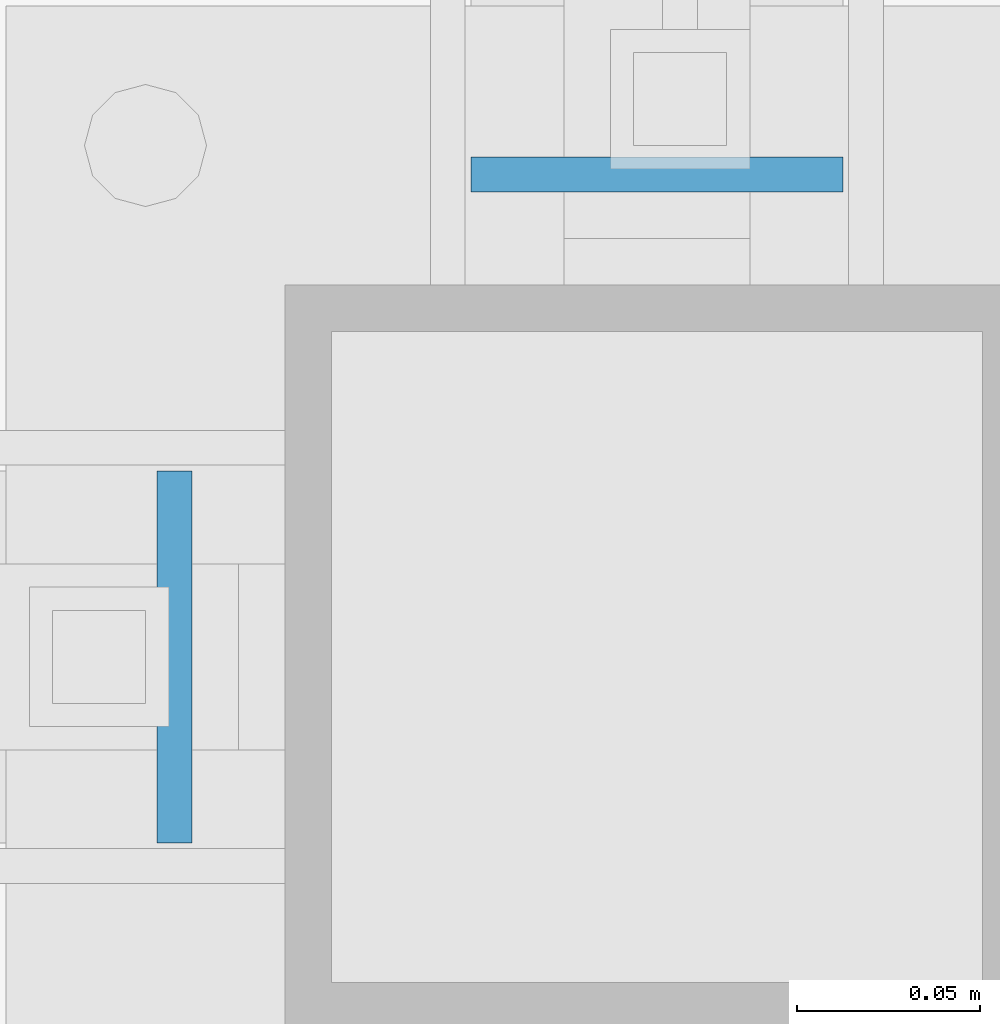
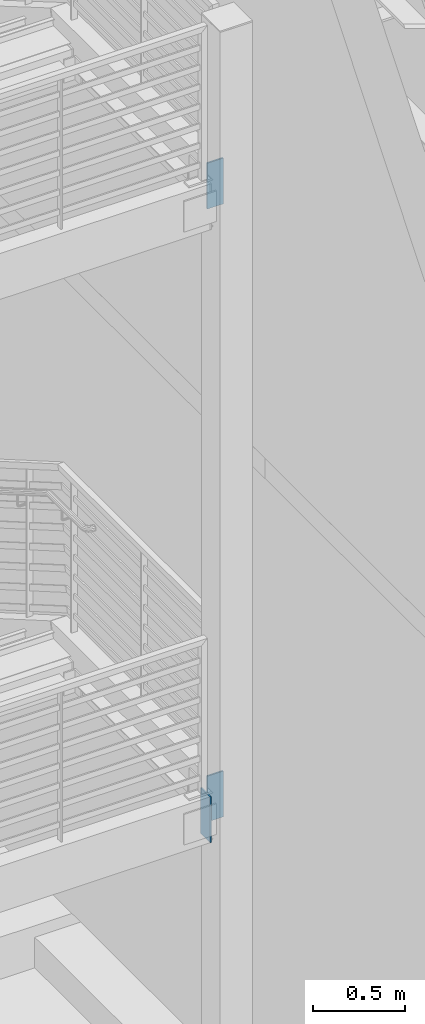
# One storey, part 427 of 1179: 3 columns, 3 elements without a shape of their own.
"""IFC2X3 building model written with IfcOpenShell, lengths in millimetres."""

from ifc_helpers import new_model, si_unit, frame, origin_with_axes, place, context, subcontext, project, spatial, faceted_brep, material, type_object, element, aggregate, save


model = new_model("IFC2X3")

# Units and contexts
model_context = context("Model", 3, precision=1e-05, world=origin_with_axes())
body_context = subcontext(model_context, "Body", "Model", "MODEL_VIEW")
ifc_project = project(units=[si_unit("LENGTHUNIT", "METRE", prefix="MILLI"), si_unit("AREAUNIT", "SQUARE_METRE"), si_unit("VOLUMEUNIT", "CUBIC_METRE"), si_unit("MASSUNIT", "GRAM", prefix="KILO"), si_unit("TIMEUNIT", "SECOND"), si_unit("PLANEANGLEUNIT", "RADIAN"), si_unit("SOLIDANGLEUNIT", "STERADIAN"), si_unit("THERMODYNAMICTEMPERATUREUNIT", "DEGREE_CELSIUS"), si_unit("LUMINOUSINTENSITYUNIT", "LUMEN")], contexts=[model_context])

# Site, building, storey
site_placement = place(None, origin_with_axes())
site = spatial("IfcSite", under=ifc_project, at=site_placement, CompositionType="ELEMENT")
building_placement = place(site_placement, origin_with_axes())
building = spatial("IfcBuilding", under=site, at=building_placement, Name="Undefined", CompositionType="ELEMENT")
storey_placement = place(building_placement, origin_with_axes())
storey = spatial("IfcBuildingStorey", under=building, at=storey_placement, Name="Undefined", CompositionType="ELEMENT", Elevation=0.0)

# Assembly, column
assembly_1_placement = place(storey_placement, origin_with_axes())
assembly_1 = element("IfcElementAssembly", 1, at=assembly_1_placement, inside=storey, Name="STRINGER", AssemblyPlace="NOTDEFINED", PredefinedType="RIGID_FRAME")
ifc_material = material(Name="STEEL/A36")
column_type = type_object("IfcColumnType", PredefinedType="NOTDEFINED")
column_1_placement = place(assembly_1_placement, frame((-254.000000004344, 30205.3624999965, 1863.77791883964), z_axis=(1.0, 0.0, 0.0), x_axis=(0.0, 0.0, 1.0)))
column_1 = element("IfcColumn", 2, at=column_1_placement, type_object=column_type, material=ifc_material, Name="PLATE", context=body_context, shape_type="Brep", body=[
    faceted_brep([(0.0, 4.76249999999982, -50.7999999999993), (0.0, 4.76249999999982, 50.7999999999993), (304.799999999999, 4.76249999999709, 50.8), (304.799999999999, 4.76249999999709, -50.8), (0.0, -4.76249999999982, 50.7999999999993), (304.799999999999, -4.76249999999709, 50.8), (0.0, -4.76249999999982, -50.7999999999993), (304.799999999999, -4.76249999999709, -50.8)], [[[0, 1, 2, 3]], [[1, 4, 5, 2]], [[4, 6, 7, 5]], [[6, 0, 3, 7]], [[5, 7, 3, 2]], [[6, 4, 1, 0]]]),
])
aggregate(assembly_1, [column_1])

assembly_2_placement = place(storey_placement, origin_with_axes())
assembly_2 = element("IfcElementAssembly", 3, at=assembly_2_placement, inside=storey, Name="STRINGER", AssemblyPlace="NOTDEFINED", PredefinedType="RIGID_FRAME")
column_2_placement = place(assembly_2_placement, frame((-253.999999995699, 30205.3625000092, 5937.24999999973), z_axis=(1.0, 0.0, 0.0), x_axis=(0.0, 0.0, 1.0)))
column_2 = element("IfcColumn", 4, at=column_2_placement, type_object=column_type, material=ifc_material, Name="PLATE", context=body_context, shape_type="Brep", body=[
    faceted_brep([(0.0, 4.76249999999982, -50.7999999999993), (0.0, 4.76249999999982, 50.7999999999993), (304.799999999999, 4.76249999999709, 50.8), (304.799999999999, 4.76249999999709, -50.8), (0.0, -4.76249999999982, 50.7999999999993), (304.799999999999, -4.76249999999709, 50.8), (0.0, -4.76249999999982, -50.7999999999993), (304.799999999999, -4.76249999999709, -50.8)], [[[0, 1, 2, 3]], [[1, 4, 5, 2]], [[4, 6, 7, 5]], [[6, 0, 3, 7]], [[5, 7, 3, 2]], [[6, 4, 1, 0]]]),
])
aggregate(assembly_2, [column_2])

assembly_3_placement = place(storey_placement, origin_with_axes())
assembly_3 = element("IfcElementAssembly", 5, at=assembly_3_placement, inside=storey, Name="BEAM", AssemblyPlace="NOTDEFINED", PredefinedType="RIGID_FRAME")
column_3_placement = place(assembly_3_placement, frame((-385.7625, 30073.6, 1863.725), z_axis=(0.0, 1.0, 0.0), x_axis=(0.0, 0.0, 1.0)))
column_3 = element("IfcColumn", 6, at=column_3_placement, type_object=column_type, material=ifc_material, Name="PLATE", context=body_context, shape_type="Brep", body=[
    faceted_brep([(0.0, 4.76249999999982, -50.7999999999993), (0.0, 4.76249999999982, 50.7999999999993), (304.799999999999, 4.76249999999709, 50.8), (304.799999999999, 4.76249999999709, -50.8), (0.0, -4.76249999999982, 50.7999999999993), (304.799999999999, -4.76249999999709, 50.8), (0.0, -4.76249999999982, -50.7999999999993), (304.799999999999, -4.76249999999709, -50.8)], [[[0, 1, 2, 3]], [[1, 4, 5, 2]], [[4, 6, 7, 5]], [[6, 0, 3, 7]], [[5, 7, 3, 2]], [[6, 4, 1, 0]]]),
])
aggregate(assembly_3, [column_3])

save(model, "model.ifc")
